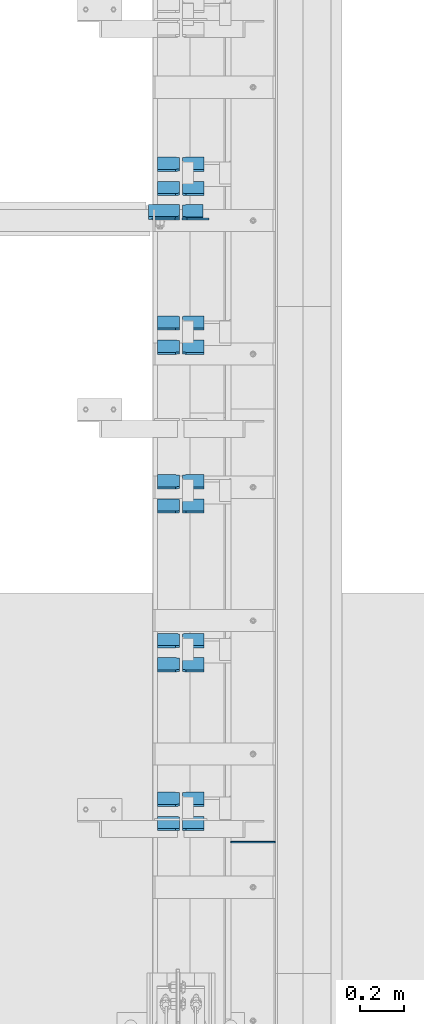
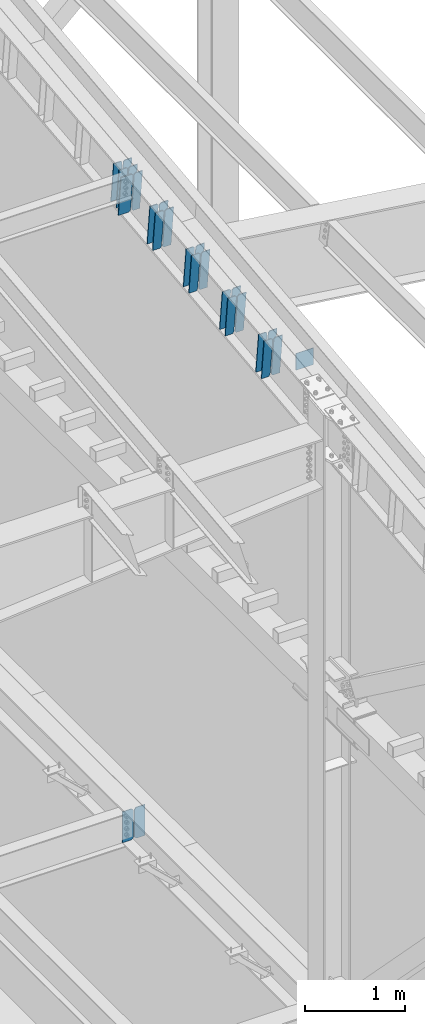
# One storey, part 1037 of 1179: 25 plates, 3 elements without a shape of their own.
"""IFC2X3 building model written with IfcOpenShell, lengths in millimetres."""

import ifcopenshell
import ifcopenshell.guid

model = None  # the IFC model being written
_history = None  # IfcOwnerHistory: only IFC2X3 demands one
_inside = {}  # id of a spatial element -> (the spatial element, [elements in it])
_under = {}  # id of a project, library or spatial element -> (it, [spatial elements below it])
_declared = {}  # id of a project -> (the project, [libraries it declares])
_typed = {}  # id of a type object -> (the type object, [elements of that type])
_made_of = {}  # id of a material, layer set ... -> (it, [elements and type objects made of it])


def new_model(schema):
    """Start an empty IFC model of exactly this schema.

    Asked for "IFC4X3", IfcOpenShell would pick the latest addendum, in which some entities
    have other attributes; the version numbers below select the first issue.
    IFC2X3 requires an IfcOwnerHistory on every rooted entity: one is made here for all.
    """
    global model, _history
    if schema == "IFC4X3":
        model = ifcopenshell.file(schema_version=(4, 3, 0, 0))
    else:
        model = ifcopenshell.file(schema=schema)
    _inside.clear()
    _under.clear()
    _declared.clear()
    _typed.clear()
    _made_of.clear()
    _history = None
    if model.schema == "IFC2X3":
        org = make("IfcOrganization", Name="unknown")
        user = make(
            "IfcPersonAndOrganization",
            ThePerson=make("IfcPerson", FamilyName="unknown"),
            TheOrganization=org,
        )
        app = make(
            "IfcApplication",
            ApplicationDeveloper=org,
            Version="unknown",
            ApplicationFullName="unknown",
            ApplicationIdentifier="unknown",
        )
        _history = make(
            "IfcOwnerHistory",
            OwningUser=user,
            OwningApplication=app,
            ChangeAction="ADDED",
            CreationDate=0,
        )
    return model


def make(cls, **values):
    """One entity of the class cls with the attributes given. An attribute that is None is left unset."""
    return model.create_entity(
        cls, **{name: value for name, value in values.items() if value is not None}
    )


def rooted(cls, **values):
    """An entity with a GlobalId (a new one), such as an element, a storey or a relation."""
    return make(cls, GlobalId=ifcopenshell.guid.new(), OwnerHistory=_history, **values)


def si_unit(unit_type, name, prefix=None):
    """IfcSIUnit, for example si_unit("LENGTHUNIT", "METRE", prefix="MILLI")."""
    return make("IfcSIUnit", UnitType=unit_type, Prefix=prefix, Name=name)


def assignment(units):
    """IfcUnitAssignment: the units of a project."""
    return None if units is None else make("IfcUnitAssignment", Units=units)


def point(xyz):
    """IfcCartesianPoint."""
    return None if xyz is None else make("IfcCartesianPoint", Coordinates=xyz)


def direction(xyz):
    """IfcDirection."""
    return None if xyz is None else make("IfcDirection", DirectionRatios=xyz)


def frame(location, z_axis=None, x_axis=None):
    """IfcAxis2Placement3D, a coordinate frame: its origin and axes. An axis left out is left unset."""
    return make(
        "IfcAxis2Placement3D",
        Location=point(location),
        Axis=direction(z_axis),
        RefDirection=direction(x_axis),
    )


def origin_with_axes():
    """The frame at (0, 0, 0) with the z axis (0, 0, 1) and the x axis (1, 0, 0) written out."""
    return frame((0.0, 0.0, 0.0), z_axis=(0.0, 0.0, 1.0), x_axis=(1.0, 0.0, 0.0))


def place(relative_to, where):
    """IfcLocalPlacement: puts the frame where relative to a parent placement (None: the world)."""
    return make(
        "IfcLocalPlacement", PlacementRelTo=relative_to, RelativePlacement=where
    )


def context(
    kind, dimensions, precision=None, world=None, true_north=None, identifier=None
):
    """IfcGeometricRepresentationContext, for example the 3D "Model" context."""
    return make(
        "IfcGeometricRepresentationContext",
        ContextIdentifier=identifier,
        ContextType=kind,
        CoordinateSpaceDimension=dimensions,
        Precision=precision,
        WorldCoordinateSystem=world,
        TrueNorth=true_north,
    )


def subcontext(parent, identifier, kind, view, scale=None):
    """IfcGeometricRepresentationSubContext, for example "Body" below "Model"."""
    return make(
        "IfcGeometricRepresentationSubContext",
        ContextIdentifier=identifier,
        ContextType=kind,
        ParentContext=parent,
        TargetScale=scale,
        TargetView=view,
    )


def project(units=None, contexts=None):
    """IfcProject with its units and contexts."""
    return rooted(
        "IfcProject",
        Name="project",
        RepresentationContexts=contexts,
        UnitsInContext=assignment(units),
    )


def spatial(cls, under=None, at=None, **own):
    """A site, building, storey or space (cls), placed at a placement, below another one or the project."""
    s = rooted(cls, ObjectPlacement=at, **own)
    if under is not None:
        _under.setdefault(under.id(), (under, []))[1].append(s)
    return s


def faces_of(points, faces, orient=None, outer=None):
    """IfcFace entities. A face is a list of loops; a loop is a list of indices into points, from 0.

    orient and outer hold one flag for each loop. By default every Orientation is true, the
    first loop of a face is its IfcFaceOuterBound and the others are IfcFaceBound.
    """
    made = []
    for i, loops in enumerate(faces):
        bounds = []
        for j, loop in enumerate(loops):
            is_outer = j == 0 if outer is None else outer[i][j]
            bounds.append(
                make(
                    "IfcFaceOuterBound" if is_outer else "IfcFaceBound",
                    Bound=make("IfcPolyLoop", Polygon=[points[k] for k in loop]),
                    Orientation=True if orient is None else orient[i][j],
                )
            )
        made.append(make("IfcFace", Bounds=bounds))
    return made


def faceted_brep(points, faces, orient=None, outer=None, voids=None):
    """IfcFacetedBrep: a solid bounded by flat faces; with voids (closed shells), ...WithVoids."""
    shared = [point(p) for p in points]
    hull = make("IfcClosedShell", CfsFaces=faces_of(shared, faces, orient, outer))
    if voids is None:
        return make("IfcFacetedBrep", Outer=hull)
    return make(
        "IfcFacetedBrepWithVoids",
        Outer=hull,
        Voids=[
            make(cls, CfsFaces=faces_of(shared, fs, o, b)) for cls, fs, o, b in voids
        ],
    )


def shape(context_of_items, identifier, shape_type, items):
    """IfcShapeRepresentation: the items that make up one representation, for example the "Body"."""
    return make(
        "IfcShapeRepresentation",
        ContextOfItems=context_of_items,
        RepresentationIdentifier=identifier,
        RepresentationType=shape_type,
        Items=items,
    )


def material(Name=None, Category=None):
    """IfcMaterial."""
    return make("IfcMaterial", Name=Name, Category=Category)


def made_of(thing, what):
    """Note that an element or type object is made of a material, layer set ...; save() writes the relation."""
    if what is not None:
        _made_of.setdefault(what.id(), (what, []))[1].append(thing)
    return thing


def type_object(cls, material=None, **own):
    """A type object (cls), such as IfcWallType, which elements share."""
    return made_of(rooted(cls, **own), material)


def element(
    cls,
    number,
    at=None,
    inside=None,
    cuts=None,
    type_object=None,
    material=None,
    context=None,
    identifier="Body",
    shape_type=None,
    held_by="IfcProductDefinitionShape",
    body=None,
    shapes=None,
    **own,
):
    """One element of the class cls, such as IfcWall. Its Tag is "e" and its number.

    at: its placement. inside: the storey or other place that contains it. cuts: it is an
    opening in that element (IfcRelVoidsElement). A single representation is given by context,
    identifier, shape_type and body (its items); several are given by shapes. held_by: the class
    of the entity that holds the representations. save() writes the other relations.
    """
    e = rooted(cls, Tag="e%d" % number, ObjectPlacement=at, **own)
    if body is not None:
        shapes = [shape(context, identifier, shape_type, body)]
    if shapes is not None:
        e.Representation = make(held_by, Representations=shapes)
    if inside is not None:
        _inside.setdefault(inside.id(), (inside, []))[1].append(e)
    if cuts is not None:
        rooted(
            "IfcRelVoidsElement", RelatingBuildingElement=cuts, RelatedOpeningElement=e
        )
    if type_object is not None:
        _typed.setdefault(type_object.id(), (type_object, []))[1].append(e)
    return made_of(e, material)


def aggregate(whole, parts):
    """IfcRelAggregates: a whole, such as a stair, and the parts it consists of."""
    return rooted("IfcRelAggregates", RelatingObject=whole, RelatedObjects=parts)


def save(model, path):
    """Write the relations noted so far, then the file.

    IfcRelAggregates (storeys below a building ...), IfcRelContainedInSpatialStructure (elements
    in a storey), IfcRelDefinesByType, IfcRelAssociatesMaterial and IfcRelDeclares: one each for
    every whole, place, type object, material and project.
    """
    for whole, parts in _under.values():
        aggregate(whole, parts)
    for where, things in _inside.values():
        rooted(
            "IfcRelContainedInSpatialStructure",
            RelatedElements=things,
            RelatingStructure=where,
        )
    for kind, things in _typed.values():
        rooted("IfcRelDefinesByType", RelatedObjects=things, RelatingType=kind)
    for what, things in _made_of.values():
        rooted("IfcRelAssociatesMaterial", RelatedObjects=things, RelatingMaterial=what)
    for by, libraries in _declared.values():
        rooted("IfcRelDeclares", RelatingContext=by, RelatedDefinitions=libraries)
    model.write(path)


model = new_model("IFC2X3")

# Units and contexts
model_context = context("Model", 3, precision=1e-05, world=origin_with_axes())
body_context = subcontext(model_context, "Body", "Model", "MODEL_VIEW")
ifc_project = project(units=[si_unit("LENGTHUNIT", "METRE", prefix="MILLI"), si_unit("AREAUNIT", "SQUARE_METRE"), si_unit("VOLUMEUNIT", "CUBIC_METRE"), si_unit("MASSUNIT", "GRAM", prefix="KILO"), si_unit("TIMEUNIT", "SECOND"), si_unit("PLANEANGLEUNIT", "RADIAN"), si_unit("SOLIDANGLEUNIT", "STERADIAN"), si_unit("THERMODYNAMICTEMPERATUREUNIT", "DEGREE_CELSIUS"), si_unit("LUMINOUSINTENSITYUNIT", "LUMEN")], contexts=[model_context])

# Site, building, storey
site_placement = place(None, origin_with_axes())
site = spatial("IfcSite", under=ifc_project, at=site_placement, CompositionType="ELEMENT")
building_placement = place(site_placement, origin_with_axes())
building = spatial("IfcBuilding", under=site, at=building_placement, Name="Undefined", CompositionType="ELEMENT")
storey_placement = place(building_placement, origin_with_axes())
storey = spatial("IfcBuildingStorey", under=building, at=storey_placement, Name="Undefined", CompositionType="ELEMENT", Elevation=0.0)

# Assembly, plate
assembly_1_placement = place(storey_placement, origin_with_axes())
assembly_1 = element("IfcElementAssembly", 1, at=assembly_1_placement, inside=storey, Name="BEAM", AssemblyPlace="NOTDEFINED", PredefinedType="RIGID_FRAME")
ifc_material = material(Name="STEEL/A36")
plate_type_1 = type_object("IfcPlateType", PredefinedType="NOTDEFINED")
plate_1_placement = place(assembly_1_placement, frame((24302.24375, 23147.3379999161, 3703.6375), z_axis=(0.0, 0.0, 1.0), x_axis=(-1.0, 0.0, 0.0)))
plate_1 = element("IfcPlate", 2, at=plate_1_placement, type_object=plate_type_1, material=ifc_material, Name="PLATE", context=body_context, shape_type="Brep", body=[
    faceted_brep([(0.0, -4.76250000000073, 22.2250003814697), (0.0, -4.76249999999709, 355.600011825562), (0.0, 4.76249999999709, 355.600011825562), (0.0, 4.76250000000073, 22.2250003814697), (22.2250003814697, -4.76249999999709, 377.825012207031), (22.2250003814697, 4.76249999999709, 377.825012207031), (127.0, -4.76249999999709, 377.825), (127.0, 4.76249999999709, 377.825), (127.0, -4.76250000000073, 0.0), (127.0, 4.76250000000073, 0.0), (22.2250003814697, -4.76250000000073, 0.0), (22.2250003814697, 4.76250000000073, 0.0)], [[[0, 1, 2, 3]], [[1, 4, 5, 2]], [[4, 6, 7, 5]], [[6, 8, 9, 7]], [[8, 10, 11, 9]], [[10, 0, 3, 11]], [[5, 7, 9, 11, 3, 2]], [[10, 8, 6, 4, 1, 0]]]),
])

# Assembly, plates
assembly_2_placement = place(storey_placement, origin_with_axes())
assembly_2 = element("IfcElementAssembly", 3, at=assembly_2_placement, inside=storey, Name="BEAM", AssemblyPlace="NOTDEFINED", PredefinedType="RIGID_FRAME")
plate_type_2 = type_object("IfcPlateType", PredefinedType="NOTDEFINED")
plate_2_placement = place(assembly_2_placement, frame((24300.65625, 23151.7261163645, 11837.4328309623), z_axis=(-1.0, 0.0, 0.0), x_axis=(0.0, 0.112284087038014, -0.993676146336441)))
plate_2 = element("IfcPlate", 4, at=plate_2_placement, type_object=plate_type_2, material=ifc_material, Name="PLATE", context=body_context, shape_type="Brep", body=[
    faceted_brep([(0.0, -6.34999999998763, 17.4624996185248), (0.0, -6.34999999999673, 139.700000000001), (-3.63797880709171e-12, 6.34999999999491, 139.700000000001), (0.0, 6.35000000000582, 17.4624996185175), (498.474999999775, -6.34999999979482, 139.700000000001), (498.474999999769, 6.35000000019681, 139.700000000001), (498.474999999775, -6.34999999979482, 17.4624996185303), (498.474999999769, 6.35000000019681, 17.4624996185303), (481.012500381255, -6.34999999980209, 0.0), (481.01250038125, 6.35000000019136, 0.0), (17.4624996185303, -6.34999999999309, 1.81898940354586e-12), (17.4624996185303, 6.34999999999854, -1.81898940354586e-12)], [[[0, 1, 2, 3]], [[1, 4, 5, 2]], [[4, 6, 7, 5]], [[6, 8, 9, 7]], [[8, 10, 11, 9]], [[10, 0, 3, 11]], [[5, 7, 9, 11, 3, 2]], [[10, 8, 6, 4, 1, 0]]]),
])
plate_type_3 = type_object("IfcPlateType", PredefinedType="NOTDEFINED")
plate_3_placement = place(assembly_2_placement, frame((24314.94375, 23207.6974234456, 11342.1101700571), z_axis=(0.0, -0.112284087038017, 0.993676146336441), x_axis=(1.0, 0.0, 0.0)))
plate_3 = element("IfcPlate", 5, at=plate_3_placement, type_object=plate_type_3, material=ifc_material, Name="PLATE", context=body_context, shape_type="Brep", body=[
    faceted_brep([(0.0, -4.76250000000073, 19.0499992370605), (0.0, -4.76250000000073, 479.425006866455), (0.0, 4.76250000000073, 479.425006866455), (0.0, 4.76250000000073, 19.0499992370605), (19.0499992370605, -4.76250000000073, 498.475006103516), (19.0499992370605, 4.76250000000073, 498.475006103516), (95.25, -4.76250000000073, 498.475006103516), (95.25, 4.76250000000073, 498.475006103516), (95.25, -4.76250000000073, 0.0), (95.25, 4.76250000000073, 0.0), (19.0499992370605, -4.76250000000073, 0.0), (19.0499992370605, 4.76250000000073, 0.0)], [[[0, 1, 2, 3]], [[1, 4, 5, 2]], [[4, 6, 7, 5]], [[6, 8, 9, 7]], [[8, 10, 11, 9]], [[10, 0, 3, 11]], [[5, 7, 9, 11, 3, 2]], [[10, 8, 6, 4, 1, 0]]]),
])

# Assembly, plate
assembly_3_placement = place(storey_placement, origin_with_axes())
assembly_3 = element("IfcElementAssembly", 6, at=assembly_3_placement, inside=storey, Name="BEAM", AssemblyPlace="NOTDEFINED", PredefinedType="RIGID_FRAME")
plate_type_4 = type_object("IfcPlateType", PredefinedType="NOTDEFINED")
plate_4_placement = place(assembly_3_placement, frame((24739.6, 20297.7749999686, 11284.4822946355), z_axis=(0.0, 0.0, -1.0), x_axis=(-1.0, 0.0, 0.0)))
plate_4 = element("IfcPlate", 7, at=plate_4_placement, type_object=plate_type_4, material=ifc_material, Name="CAP_PLATE", context=body_context, shape_type="Brep", body=[
    faceted_brep([(0.0, -3.17500000000109, 0.0), (0.0, -3.17499999999927, 204.492999998953), (0.0, 3.17499999999927, 204.492999998953), (0.0, 3.17500000000109, 7.27595761418343e-12), (203.199999999997, -3.17499999999927, 204.492999998953), (203.199999999997, 3.17499999999927, 204.492999998953), (203.199999999997, -3.17499999999927, 3.63797880709171e-12), (203.199999999997, 3.17499999999382, -3.63797880709171e-12)], [[[0, 1, 2, 3]], [[1, 4, 5, 2]], [[4, 6, 7, 5]], [[6, 0, 3, 7]], [[5, 7, 3, 2]], [[6, 4, 1, 0]]]),
])
aggregate(assembly_3, [plate_4])

# Plate
plate_type_5 = type_object("IfcPlateType", PredefinedType="NOTDEFINED")
plate_5_placement = place(assembly_2_placement, frame((24414.1625, 20410.8496242979, 11026.0700770467), z_axis=(0.0, -0.112284087038017, 0.993676146336441), x_axis=(-1.0, 0.0, 0.0)))
plate_5 = element("IfcPlate", 8, at=plate_5_placement, type_object=plate_type_5, material=ifc_material, Name="PLATE", context=body_context, shape_type="Brep", body=[
    faceted_brep([(0.0, -4.76249999999709, 0.0), (0.0, -4.76250000020082, 498.474999998594), (0.0, 4.76249999979336, 498.474999998596), (0.0, 4.76249999999709, 0.0), (81.7562503814697, -4.76250000020082, 498.474999998594), (81.7562503814697, 4.76249999979336, 498.474999998596), (99.21875, -4.76250000019354, 481.012500380073), (99.21875, 4.76249999980064, 481.012500380079), (99.21875, -4.76250000000437, 17.4624996185212), (99.21875, 4.76249999998981, 17.4624996185248), (81.7562503814697, -4.76250000000073, 0.0), (81.7562503814697, 4.76249999999709, 3.63797880709171e-12)], [[[0, 1, 2, 3]], [[1, 4, 5, 2]], [[4, 6, 7, 5]], [[6, 8, 9, 7]], [[8, 10, 11, 9]], [[10, 0, 3, 11]], [[5, 7, 9, 11, 3, 2]], [[10, 8, 6, 4, 1, 0]]]),
])

plate_6_placement = place(assembly_2_placement, frame((24300.65625, 20410.8496242979, 11026.0700770467), z_axis=(0.0, -0.112284087038017, 0.993676146336441), x_axis=(-1.0, 0.0, 0.0)))
plate_6 = element("IfcPlate", 9, at=plate_6_placement, type_object=plate_type_5, material=ifc_material, Name="PLATE", context=body_context, shape_type="Brep", body=[
    faceted_brep([(-1.81898940354586e-12, -4.76249999999345, 17.4624996185303), (0.0, -4.76250000019354, 481.012500380073), (0.0, 4.76249999980064, 481.012500380079), (1.81898940354586e-12, 4.76250000000073, 17.4624996185303), (17.4624996185303, -4.76250000020082, 498.474999998594), (17.4624996185303, 4.76249999979336, 498.474999998596), (99.2187497618652, -4.76249999998072, 498.475), (99.2187499999927, 4.76250000001892, 498.475), (99.21875, -4.76250000000073, 0.0), (99.21875, 4.76249999999709, 3.63797880709171e-12), (17.4624996185157, -4.76250000000073, 0.0), (17.4624996185212, 4.76249999999345, 0.0)], [[[0, 1, 2, 3]], [[1, 4, 5, 2]], [[4, 6, 7, 5]], [[6, 8, 9, 7]], [[8, 10, 11, 9]], [[10, 0, 3, 11]], [[5, 7, 9, 11, 3, 2]], [[10, 8, 6, 4, 1, 0]]]),
])

plate_7_placement = place(assembly_2_placement, frame((24414.1625, 20521.2718860595, 11038.5476462187), z_axis=(0.0, -0.112284087038017, 0.993676146336441), x_axis=(-1.0, 0.0, 0.0)))
plate_7 = element("IfcPlate", 10, at=plate_7_placement, type_object=plate_type_5, material=ifc_material, Name="PLATE", context=body_context, shape_type="Brep", body=[
    faceted_brep([(0.0, -4.76249999999709, 0.0), (0.0, -4.76250000020082, 498.474999998594), (0.0, 4.76249999979336, 498.474999998596), (0.0, 4.76249999999709, 0.0), (81.7562503814697, -4.76250000020082, 498.474999998594), (81.7562503814697, 4.76249999979336, 498.474999998596), (99.21875, -4.76250000019354, 481.012500380073), (99.21875, 4.76249999980064, 481.012500380079), (99.21875, -4.76250000000437, 17.4624996185212), (99.21875, 4.76249999998981, 17.4624996185248), (81.7562503814697, -4.76250000000073, 0.0), (81.7562503814697, 4.76249999999709, 3.63797880709171e-12)], [[[0, 1, 2, 3]], [[1, 4, 5, 2]], [[4, 6, 7, 5]], [[6, 8, 9, 7]], [[8, 10, 11, 9]], [[10, 0, 3, 11]], [[5, 7, 9, 11, 3, 2]], [[10, 8, 6, 4, 1, 0]]]),
])

plate_8_placement = place(assembly_2_placement, frame((24300.65625, 20521.2718860595, 11038.5476462187), z_axis=(0.0, -0.112284087038017, 0.993676146336441), x_axis=(-1.0, 0.0, 0.0)))
plate_8 = element("IfcPlate", 11, at=plate_8_placement, type_object=plate_type_5, material=ifc_material, Name="PLATE", context=body_context, shape_type="Brep", body=[
    faceted_brep([(-1.81898940354586e-12, -4.76249999999345, 17.4624996185303), (0.0, -4.76250000019354, 481.012500380073), (0.0, 4.76249999980064, 481.012500380079), (1.81898940354586e-12, 4.76250000000073, 17.4624996185303), (17.4624996185303, -4.76250000020082, 498.474999998594), (17.4624996185303, 4.76249999979336, 498.474999998596), (99.2187497618652, -4.76249999998072, 498.475), (99.2187499999927, 4.76250000001892, 498.475), (99.21875, -4.76250000000073, 0.0), (99.21875, 4.76249999999709, 3.63797880709171e-12), (17.4624996185157, -4.76250000000073, 0.0), (17.4624996185212, 4.76249999999345, 0.0)], [[[0, 1, 2, 3]], [[1, 4, 5, 2]], [[4, 6, 7, 5]], [[6, 8, 9, 7]], [[8, 10, 11, 9]], [[10, 0, 3, 11]], [[5, 7, 9, 11, 3, 2]], [[10, 8, 6, 4, 1, 0]]]),
])

plate_9_placement = place(assembly_2_placement, frame((24414.1625, 21136.7563455912, 11108.0965740853), z_axis=(0.0, -0.112284087038017, 0.993676146336441), x_axis=(-1.0, 0.0, 0.0)))
plate_9 = element("IfcPlate", 12, at=plate_9_placement, type_object=plate_type_5, material=ifc_material, Name="PLATE", context=body_context, shape_type="Brep", body=[
    faceted_brep([(0.0, -4.76249999999709, 0.0), (0.0, -4.76250000020082, 498.474999998594), (0.0, 4.76249999979336, 498.474999998596), (0.0, 4.76249999999709, 0.0), (81.7562503814697, -4.76250000020082, 498.474999998594), (81.7562503814697, 4.76249999979336, 498.474999998596), (99.21875, -4.76250000019354, 481.012500380073), (99.21875, 4.76249999980064, 481.012500380079), (99.21875, -4.76250000000437, 17.4624996185212), (99.21875, 4.76249999998981, 17.4624996185248), (81.7562503814697, -4.76250000000073, 0.0), (81.7562503814697, 4.76249999999709, 3.63797880709171e-12)], [[[0, 1, 2, 3]], [[1, 4, 5, 2]], [[4, 6, 7, 5]], [[6, 8, 9, 7]], [[8, 10, 11, 9]], [[10, 0, 3, 11]], [[5, 7, 9, 11, 3, 2]], [[10, 8, 6, 4, 1, 0]]]),
])

plate_10_placement = place(assembly_2_placement, frame((24300.65625, 21136.7563455912, 11108.0965740853), z_axis=(0.0, -0.112284087038017, 0.993676146336441), x_axis=(-1.0, 0.0, 0.0)))
plate_10 = element("IfcPlate", 13, at=plate_10_placement, type_object=plate_type_5, material=ifc_material, Name="PLATE", context=body_context, shape_type="Brep", body=[
    faceted_brep([(-1.81898940354586e-12, -4.76249999999345, 17.4624996185303), (0.0, -4.76250000019354, 481.012500380073), (0.0, 4.76249999980064, 481.012500380079), (1.81898940354586e-12, 4.76250000000073, 17.4624996185303), (17.4624996185303, -4.76250000020082, 498.474999998594), (17.4624996185303, 4.76249999979336, 498.474999998596), (99.2187497618652, -4.76249999998072, 498.475), (99.2187499999927, 4.76250000001892, 498.475), (99.21875, -4.76250000000073, 0.0), (99.21875, 4.76249999999709, 3.63797880709171e-12), (17.4624996185157, -4.76250000000073, 0.0), (17.4624996185212, 4.76249999999345, 0.0)], [[[0, 1, 2, 3]], [[1, 4, 5, 2]], [[4, 6, 7, 5]], [[6, 8, 9, 7]], [[8, 10, 11, 9]], [[10, 0, 3, 11]], [[5, 7, 9, 11, 3, 2]], [[10, 8, 6, 4, 1, 0]]]),
])

plate_11_placement = place(assembly_2_placement, frame((24414.1625, 21247.1786073528, 11120.5741432574), z_axis=(0.0, -0.112284087038017, 0.993676146336441), x_axis=(-1.0, 0.0, 0.0)))
plate_11 = element("IfcPlate", 14, at=plate_11_placement, type_object=plate_type_5, material=ifc_material, Name="PLATE", context=body_context, shape_type="Brep", body=[
    faceted_brep([(0.0, -4.76249999999709, 0.0), (0.0, -4.76250000020082, 498.474999998594), (0.0, 4.76249999979336, 498.474999998596), (0.0, 4.76249999999709, 0.0), (81.7562503814697, -4.76250000020082, 498.474999998594), (81.7562503814697, 4.76249999979336, 498.474999998596), (99.21875, -4.76250000019354, 481.012500380073), (99.21875, 4.76249999980064, 481.012500380079), (99.21875, -4.76250000000437, 17.4624996185212), (99.21875, 4.76249999998981, 17.4624996185248), (81.7562503814697, -4.76250000000073, 0.0), (81.7562503814697, 4.76249999999709, 3.63797880709171e-12)], [[[0, 1, 2, 3]], [[1, 4, 5, 2]], [[4, 6, 7, 5]], [[6, 8, 9, 7]], [[8, 10, 11, 9]], [[10, 0, 3, 11]], [[5, 7, 9, 11, 3, 2]], [[10, 8, 6, 4, 1, 0]]]),
])

plate_12_placement = place(assembly_2_placement, frame((24300.65625, 21247.1786073528, 11120.5741432574), z_axis=(0.0, -0.112284087038017, 0.993676146336441), x_axis=(-1.0, 0.0, 0.0)))
plate_12 = element("IfcPlate", 15, at=plate_12_placement, type_object=plate_type_5, material=ifc_material, Name="PLATE", context=body_context, shape_type="Brep", body=[
    faceted_brep([(-1.81898940354586e-12, -4.76249999999345, 17.4624996185303), (0.0, -4.76250000019354, 481.012500380073), (0.0, 4.76249999980064, 481.012500380079), (1.81898940354586e-12, 4.76250000000073, 17.4624996185303), (17.4624996185303, -4.76250000020082, 498.474999998594), (17.4624996185303, 4.76249999979336, 498.474999998596), (99.2187497618652, -4.76249999998072, 498.475), (99.2187499999927, 4.76250000001892, 498.475), (99.21875, -4.76250000000073, 0.0), (99.21875, 4.76249999999709, 3.63797880709171e-12), (17.4624996185157, -4.76250000000073, 0.0), (17.4624996185212, 4.76249999999345, 0.0)], [[[0, 1, 2, 3]], [[1, 4, 5, 2]], [[4, 6, 7, 5]], [[6, 8, 9, 7]], [[8, 10, 11, 9]], [[10, 0, 3, 11]], [[5, 7, 9, 11, 3, 2]], [[10, 8, 6, 4, 1, 0]]]),
])

plate_13_placement = place(assembly_2_placement, frame((24414.1625, 21862.6630668845, 11190.123071124), z_axis=(0.0, -0.112284087038017, 0.993676146336441), x_axis=(-1.0, 0.0, 0.0)))
plate_13 = element("IfcPlate", 16, at=plate_13_placement, type_object=plate_type_5, material=ifc_material, Name="PLATE", context=body_context, shape_type="Brep", body=[
    faceted_brep([(0.0, -4.76249999999709, 0.0), (0.0, -4.76250000020082, 498.474999998594), (0.0, 4.76249999979336, 498.474999998596), (0.0, 4.76249999999709, 0.0), (81.7562503814697, -4.76250000020082, 498.474999998594), (81.7562503814697, 4.76249999979336, 498.474999998596), (99.21875, -4.76250000019354, 481.012500380073), (99.21875, 4.76249999980064, 481.012500380079), (99.21875, -4.76250000000437, 17.4624996185212), (99.21875, 4.76249999998981, 17.4624996185248), (81.7562503814697, -4.76250000000073, 0.0), (81.7562503814697, 4.76249999999709, 3.63797880709171e-12)], [[[0, 1, 2, 3]], [[1, 4, 5, 2]], [[4, 6, 7, 5]], [[6, 8, 9, 7]], [[8, 10, 11, 9]], [[10, 0, 3, 11]], [[5, 7, 9, 11, 3, 2]], [[10, 8, 6, 4, 1, 0]]]),
])

plate_14_placement = place(assembly_2_placement, frame((24300.65625, 21862.6630668845, 11190.123071124), z_axis=(0.0, -0.112284087038017, 0.993676146336441), x_axis=(-1.0, 0.0, 0.0)))
plate_14 = element("IfcPlate", 17, at=plate_14_placement, type_object=plate_type_5, material=ifc_material, Name="PLATE", context=body_context, shape_type="Brep", body=[
    faceted_brep([(-1.81898940354586e-12, -4.76249999999345, 17.4624996185303), (0.0, -4.76250000019354, 481.012500380073), (0.0, 4.76249999980064, 481.012500380079), (1.81898940354586e-12, 4.76250000000073, 17.4624996185303), (17.4624996185303, -4.76250000020082, 498.474999998594), (17.4624996185303, 4.76249999979336, 498.474999998596), (99.2187497618652, -4.76249999998072, 498.475), (99.2187499999927, 4.76250000001892, 498.475), (99.21875, -4.76250000000073, 0.0), (99.21875, 4.76249999999709, 3.63797880709171e-12), (17.4624996185157, -4.76250000000073, 0.0), (17.4624996185212, 4.76249999999345, 0.0)], [[[0, 1, 2, 3]], [[1, 4, 5, 2]], [[4, 6, 7, 5]], [[6, 8, 9, 7]], [[8, 10, 11, 9]], [[10, 0, 3, 11]], [[5, 7, 9, 11, 3, 2]], [[10, 8, 6, 4, 1, 0]]]),
])

plate_15_placement = place(assembly_2_placement, frame((24414.1625, 21973.0853286461, 11202.6006402961), z_axis=(0.0, -0.112284087038017, 0.993676146336441), x_axis=(-1.0, 0.0, 0.0)))
plate_15 = element("IfcPlate", 18, at=plate_15_placement, type_object=plate_type_5, material=ifc_material, Name="PLATE", context=body_context, shape_type="Brep", body=[
    faceted_brep([(0.0, -4.76249999999709, 0.0), (0.0, -4.76250000020082, 498.474999998594), (0.0, 4.76249999979336, 498.474999998596), (0.0, 4.76249999999709, 0.0), (81.7562503814697, -4.76250000020082, 498.474999998594), (81.7562503814697, 4.76249999979336, 498.474999998596), (99.21875, -4.76250000019354, 481.012500380073), (99.21875, 4.76249999980064, 481.012500380079), (99.21875, -4.76250000000437, 17.4624996185212), (99.21875, 4.76249999998981, 17.4624996185248), (81.7562503814697, -4.76250000000073, 0.0), (81.7562503814697, 4.76249999999709, 3.63797880709171e-12)], [[[0, 1, 2, 3]], [[1, 4, 5, 2]], [[4, 6, 7, 5]], [[6, 8, 9, 7]], [[8, 10, 11, 9]], [[10, 0, 3, 11]], [[5, 7, 9, 11, 3, 2]], [[10, 8, 6, 4, 1, 0]]]),
])

plate_16_placement = place(assembly_2_placement, frame((24300.65625, 21973.0853286461, 11202.6006402961), z_axis=(0.0, -0.112284087038017, 0.993676146336441), x_axis=(-1.0, 0.0, 0.0)))
plate_16 = element("IfcPlate", 19, at=plate_16_placement, type_object=plate_type_5, material=ifc_material, Name="PLATE", context=body_context, shape_type="Brep", body=[
    faceted_brep([(-1.81898940354586e-12, -4.76249999999345, 17.4624996185303), (0.0, -4.76250000019354, 481.012500380073), (0.0, 4.76249999980064, 481.012500380079), (1.81898940354586e-12, 4.76250000000073, 17.4624996185303), (17.4624996185303, -4.76250000020082, 498.474999998594), (17.4624996185303, 4.76249999979336, 498.474999998596), (99.2187497618652, -4.76249999998072, 498.475), (99.2187499999927, 4.76250000001892, 498.475), (99.21875, -4.76250000000073, 0.0), (99.21875, 4.76249999999709, 3.63797880709171e-12), (17.4624996185157, -4.76250000000073, 0.0), (17.4624996185212, 4.76249999999345, 0.0)], [[[0, 1, 2, 3]], [[1, 4, 5, 2]], [[4, 6, 7, 5]], [[6, 8, 9, 7]], [[8, 10, 11, 9]], [[10, 0, 3, 11]], [[5, 7, 9, 11, 3, 2]], [[10, 8, 6, 4, 1, 0]]]),
])

plate_17_placement = place(assembly_2_placement, frame((24414.1625, 22588.5697881779, 11272.1495681627), z_axis=(0.0, -0.112284087038017, 0.993676146336441), x_axis=(-1.0, 0.0, 0.0)))
plate_17 = element("IfcPlate", 20, at=plate_17_placement, type_object=plate_type_5, material=ifc_material, Name="PLATE", context=body_context, shape_type="Brep", body=[
    faceted_brep([(0.0, -4.76249999999709, 0.0), (0.0, -4.76250000020082, 498.474999998594), (0.0, 4.76249999979336, 498.474999998596), (0.0, 4.76249999999709, 0.0), (81.7562503814697, -4.76250000020082, 498.474999998594), (81.7562503814697, 4.76249999979336, 498.474999998596), (99.21875, -4.76250000019354, 481.012500380073), (99.21875, 4.76249999980064, 481.012500380079), (99.21875, -4.76250000000437, 17.4624996185212), (99.21875, 4.76249999998981, 17.4624996185248), (81.7562503814697, -4.76250000000073, 0.0), (81.7562503814697, 4.76249999999709, 3.63797880709171e-12)], [[[0, 1, 2, 3]], [[1, 4, 5, 2]], [[4, 6, 7, 5]], [[6, 8, 9, 7]], [[8, 10, 11, 9]], [[10, 0, 3, 11]], [[5, 7, 9, 11, 3, 2]], [[10, 8, 6, 4, 1, 0]]]),
])

plate_18_placement = place(assembly_2_placement, frame((24300.65625, 22588.5697881779, 11272.1495681627), z_axis=(0.0, -0.112284087038017, 0.993676146336441), x_axis=(-1.0, 0.0, 0.0)))
plate_18 = element("IfcPlate", 21, at=plate_18_placement, type_object=plate_type_5, material=ifc_material, Name="PLATE", context=body_context, shape_type="Brep", body=[
    faceted_brep([(-1.81898940354586e-12, -4.76249999999345, 17.4624996185303), (0.0, -4.76250000019354, 481.012500380073), (0.0, 4.76249999980064, 481.012500380079), (1.81898940354586e-12, 4.76250000000073, 17.4624996185303), (17.4624996185303, -4.76250000020082, 498.474999998594), (17.4624996185303, 4.76249999979336, 498.474999998596), (99.2187497618652, -4.76249999998072, 498.475), (99.2187499999927, 4.76250000001892, 498.475), (99.21875, -4.76250000000073, 0.0), (99.21875, 4.76249999999709, 3.63797880709171e-12), (17.4624996185157, -4.76250000000073, 0.0), (17.4624996185212, 4.76249999999345, 0.0)], [[[0, 1, 2, 3]], [[1, 4, 5, 2]], [[4, 6, 7, 5]], [[6, 8, 9, 7]], [[8, 10, 11, 9]], [[10, 0, 3, 11]], [[5, 7, 9, 11, 3, 2]], [[10, 8, 6, 4, 1, 0]]]),
])

plate_19_placement = place(assembly_2_placement, frame((24414.1625, 22698.9920499394, 11284.6271373348), z_axis=(0.0, -0.112284087038017, 0.993676146336441), x_axis=(-1.0, 0.0, 0.0)))
plate_19 = element("IfcPlate", 22, at=plate_19_placement, type_object=plate_type_5, material=ifc_material, Name="PLATE", context=body_context, shape_type="Brep", body=[
    faceted_brep([(0.0, -4.76249999999709, 0.0), (0.0, -4.76250000020082, 498.474999998594), (0.0, 4.76249999979336, 498.474999998596), (0.0, 4.76249999999709, 0.0), (81.7562503814697, -4.76250000020082, 498.474999998594), (81.7562503814697, 4.76249999979336, 498.474999998596), (99.21875, -4.76250000019354, 481.012500380073), (99.21875, 4.76249999980064, 481.012500380079), (99.21875, -4.76250000000437, 17.4624996185212), (99.21875, 4.76249999998981, 17.4624996185248), (81.7562503814697, -4.76250000000073, 0.0), (81.7562503814697, 4.76249999999709, 3.63797880709171e-12)], [[[0, 1, 2, 3]], [[1, 4, 5, 2]], [[4, 6, 7, 5]], [[6, 8, 9, 7]], [[8, 10, 11, 9]], [[10, 0, 3, 11]], [[5, 7, 9, 11, 3, 2]], [[10, 8, 6, 4, 1, 0]]]),
])

plate_20_placement = place(assembly_2_placement, frame((24300.65625, 22698.9920499394, 11284.6271373348), z_axis=(0.0, -0.112284087038017, 0.993676146336441), x_axis=(-1.0, 0.0, 0.0)))
plate_20 = element("IfcPlate", 23, at=plate_20_placement, type_object=plate_type_5, material=ifc_material, Name="PLATE", context=body_context, shape_type="Brep", body=[
    faceted_brep([(-1.81898940354586e-12, -4.76249999999345, 17.4624996185303), (0.0, -4.76250000019354, 481.012500380073), (0.0, 4.76249999980064, 481.012500380079), (1.81898940354586e-12, 4.76250000000073, 17.4624996185303), (17.4624996185303, -4.76250000020082, 498.474999998594), (17.4624996185303, 4.76249999979336, 498.474999998596), (99.2187497618652, -4.76249999998072, 498.475), (99.2187499999927, 4.76250000001892, 498.475), (99.21875, -4.76250000000073, 0.0), (99.21875, 4.76249999999709, 3.63797880709171e-12), (17.4624996185157, -4.76250000000073, 0.0), (17.4624996185212, 4.76249999999345, 0.0)], [[[0, 1, 2, 3]], [[1, 4, 5, 2]], [[4, 6, 7, 5]], [[6, 8, 9, 7]], [[8, 10, 11, 9]], [[10, 0, 3, 11]], [[5, 7, 9, 11, 3, 2]], [[10, 8, 6, 4, 1, 0]]]),
])

plate_21_placement = place(assembly_2_placement, frame((24414.1625, 23314.4765094712, 11354.1760652014), z_axis=(0.0, -0.112284087038017, 0.993676146336441), x_axis=(-1.0, 0.0, 0.0)))
plate_21 = element("IfcPlate", 24, at=plate_21_placement, type_object=plate_type_5, material=ifc_material, Name="PLATE", context=body_context, shape_type="Brep", body=[
    faceted_brep([(0.0, -4.76249999999709, 0.0), (0.0, -4.76250000020082, 498.474999998594), (0.0, 4.76249999979336, 498.474999998596), (0.0, 4.76249999999709, 0.0), (81.7562503814697, -4.76250000020082, 498.474999998594), (81.7562503814697, 4.76249999979336, 498.474999998596), (99.21875, -4.76250000019354, 481.012500380073), (99.21875, 4.76249999980064, 481.012500380079), (99.21875, -4.76250000000437, 17.4624996185212), (99.21875, 4.76249999998981, 17.4624996185248), (81.7562503814697, -4.76250000000073, 0.0), (81.7562503814697, 4.76249999999709, 3.63797880709171e-12)], [[[0, 1, 2, 3]], [[1, 4, 5, 2]], [[4, 6, 7, 5]], [[6, 8, 9, 7]], [[8, 10, 11, 9]], [[10, 0, 3, 11]], [[5, 7, 9, 11, 3, 2]], [[10, 8, 6, 4, 1, 0]]]),
])

plate_22_placement = place(assembly_2_placement, frame((24300.65625, 23314.4765094712, 11354.1760652014), z_axis=(0.0, -0.112284087038017, 0.993676146336441), x_axis=(-1.0, 0.0, 0.0)))
plate_22 = element("IfcPlate", 25, at=plate_22_placement, type_object=plate_type_5, material=ifc_material, Name="PLATE", context=body_context, shape_type="Brep", body=[
    faceted_brep([(-1.81898940354586e-12, -4.76249999999345, 17.4624996185303), (0.0, -4.76250000019354, 481.012500380073), (0.0, 4.76249999980064, 481.012500380079), (1.81898940354586e-12, 4.76250000000073, 17.4624996185303), (17.4624996185303, -4.76250000020082, 498.474999998594), (17.4624996185303, 4.76249999979336, 498.474999998596), (99.2187497618652, -4.76249999998072, 498.475), (99.2187499999927, 4.76250000001892, 498.475), (99.21875, -4.76250000000073, 0.0), (99.21875, 4.76249999999709, 3.63797880709171e-12), (17.4624996185157, -4.76250000000073, 0.0), (17.4624996185212, 4.76249999999345, 0.0)], [[[0, 1, 2, 3]], [[1, 4, 5, 2]], [[4, 6, 7, 5]], [[6, 8, 9, 7]], [[8, 10, 11, 9]], [[10, 0, 3, 11]], [[5, 7, 9, 11, 3, 2]], [[10, 8, 6, 4, 1, 0]]]),
])

plate_23_placement = place(assembly_2_placement, frame((24414.1625, 23424.8987712328, 11366.6536343735), z_axis=(0.0, -0.112284087038017, 0.993676146336441), x_axis=(-1.0, 0.0, 0.0)))
plate_23 = element("IfcPlate", 26, at=plate_23_placement, type_object=plate_type_5, material=ifc_material, Name="PLATE", context=body_context, shape_type="Brep", body=[
    faceted_brep([(0.0, -4.76249999999709, 0.0), (0.0, -4.76250000020082, 498.474999998594), (0.0, 4.76249999979336, 498.474999998596), (0.0, 4.76249999999709, 0.0), (81.7562503814697, -4.76250000020082, 498.474999998594), (81.7562503814697, 4.76249999979336, 498.474999998596), (99.21875, -4.76250000019354, 481.012500380073), (99.21875, 4.76249999980064, 481.012500380079), (99.21875, -4.76250000000437, 17.4624996185212), (99.21875, 4.76249999998981, 17.4624996185248), (81.7562503814697, -4.76250000000073, 0.0), (81.7562503814697, 4.76249999999709, 3.63797880709171e-12)], [[[0, 1, 2, 3]], [[1, 4, 5, 2]], [[4, 6, 7, 5]], [[6, 8, 9, 7]], [[8, 10, 11, 9]], [[10, 0, 3, 11]], [[5, 7, 9, 11, 3, 2]], [[10, 8, 6, 4, 1, 0]]]),
])

plate_24_placement = place(assembly_2_placement, frame((24300.65625, 23424.8987712328, 11366.6536343735), z_axis=(0.0, -0.112284087038017, 0.993676146336441), x_axis=(-1.0, 0.0, 0.0)))
plate_24 = element("IfcPlate", 27, at=plate_24_placement, type_object=plate_type_5, material=ifc_material, Name="PLATE", context=body_context, shape_type="Brep", body=[
    faceted_brep([(-1.81898940354586e-12, -4.76249999999345, 17.4624996185303), (0.0, -4.76250000019354, 481.012500380073), (0.0, 4.76249999980064, 481.012500380079), (1.81898940354586e-12, 4.76250000000073, 17.4624996185303), (17.4624996185303, -4.76250000020082, 498.474999998594), (17.4624996185303, 4.76249999979336, 498.474999998596), (99.2187497618652, -4.76249999998072, 498.475), (99.2187499999927, 4.76250000001892, 498.475), (99.21875, -4.76250000000073, 0.0), (99.21875, 4.76249999999709, 3.63797880709171e-12), (17.4624996185157, -4.76250000000073, 0.0), (17.4624996185212, 4.76249999999345, 0.0)], [[[0, 1, 2, 3]], [[1, 4, 5, 2]], [[4, 6, 7, 5]], [[6, 8, 9, 7]], [[8, 10, 11, 9]], [[10, 0, 3, 11]], [[5, 7, 9, 11, 3, 2]], [[10, 8, 6, 4, 1, 0]]]),
])

aggregate(assembly_2, [plate_3, plate_2, plate_5, plate_6, plate_7, plate_8, plate_9, plate_10, plate_11, plate_12, plate_13, plate_14, plate_15, plate_16, plate_17, plate_18, plate_19, plate_20, plate_21, plate_22, plate_23, plate_24])

plate_type_6 = type_object("IfcPlateType", PredefinedType="NOTDEFINED")
plate_25_placement = place(assembly_1_placement, frame((24313.35625, 23147.3375, 3703.6375), z_axis=(0.0, 0.0, 1.0), x_axis=(1.0, 0.0, 0.0)))
plate_25 = element("IfcPlate", 28, at=plate_25_placement, type_object=plate_type_6, material=ifc_material, Name="PLATE", context=body_context, shape_type="Brep", body=[
    faceted_brep([(0.0, -4.76250000000073, 22.2250003814697), (0.0, -4.76249999999709, 355.600011825562), (0.0, 4.76249999999709, 355.600011825562), (0.0, 4.76250000000073, 22.2250003814697), (22.2250003814697, -4.76249999999709, 377.825012207031), (22.2250003814697, 4.76249999999709, 377.825012207031), (123.03125, -4.76250000000073, 377.825012207031), (123.03125, 4.76250000000073, 377.825012207031), (123.03125, -4.76250000000073, 0.0), (123.03125, 4.76250000000073, 0.0), (22.2250003814697, -4.76250000000073, 0.0), (22.2250003814697, 4.76250000000073, 0.0)], [[[0, 1, 2, 3]], [[1, 4, 5, 2]], [[4, 6, 7, 5]], [[6, 8, 9, 7]], [[8, 10, 11, 9]], [[10, 0, 3, 11]], [[5, 7, 9, 11, 3, 2]], [[10, 8, 6, 4, 1, 0]]]),
])

aggregate(assembly_1, [plate_25, plate_1])

save(model, "model.ifc")
